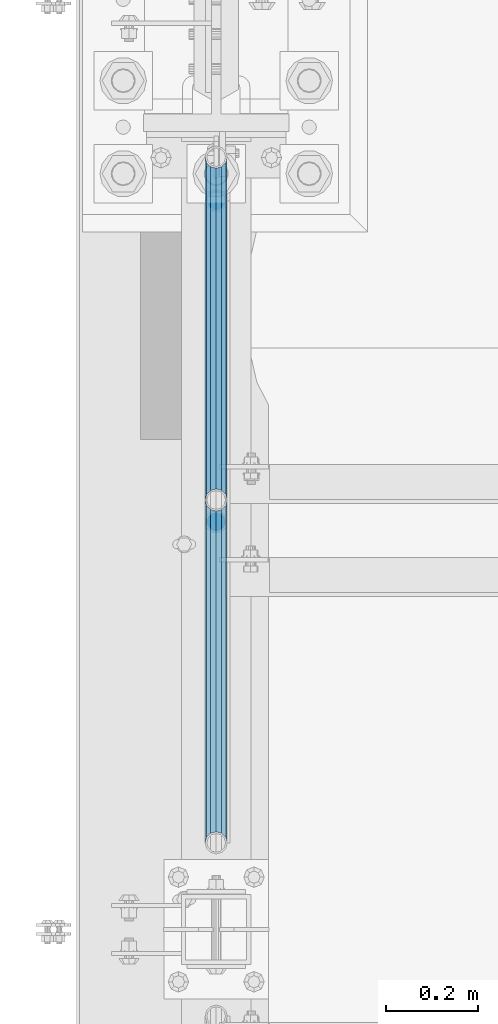
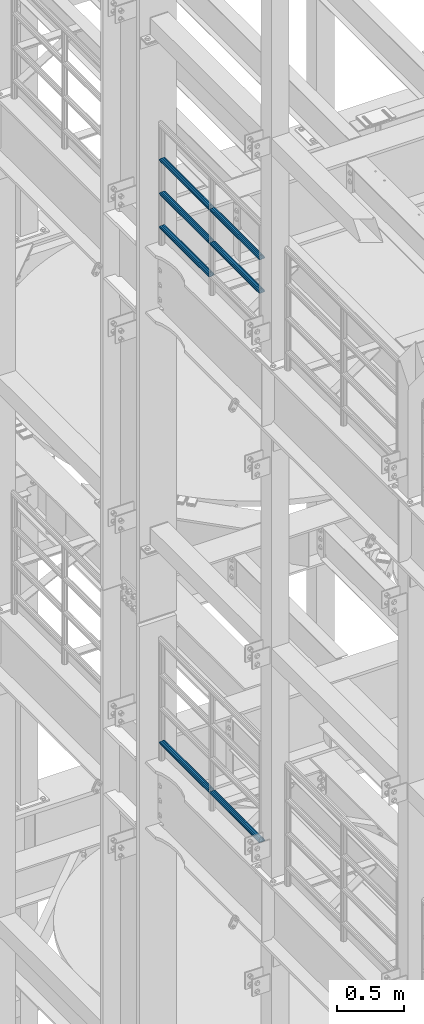
# One storey, part 1283 of 1876: 7 beams, 2 elements without a shape of their own.
"""IFC2X3 building model written with IfcOpenShell, lengths in millimetres."""

from ifc_helpers import new_model, si_unit, frame, origin_with_axes, place, context, subcontext, project, spatial, faceted_brep, material, type_object, element, aggregate, save


model = new_model("IFC2X3")

# Units and contexts
model_context = context("Model", 3, precision=1e-05, world=origin_with_axes())
body_context = subcontext(model_context, "Body", "Model", "MODEL_VIEW")
ifc_project = project(units=[si_unit("LENGTHUNIT", "METRE", prefix="MILLI"), si_unit("AREAUNIT", "SQUARE_METRE"), si_unit("VOLUMEUNIT", "CUBIC_METRE"), si_unit("MASSUNIT", "GRAM", prefix="KILO"), si_unit("TIMEUNIT", "SECOND"), si_unit("PLANEANGLEUNIT", "RADIAN"), si_unit("SOLIDANGLEUNIT", "STERADIAN"), si_unit("THERMODYNAMICTEMPERATUREUNIT", "DEGREE_CELSIUS"), si_unit("LUMINOUSINTENSITYUNIT", "LUMEN")], contexts=[model_context])

# Site, building, storey
site_placement = place(None, origin_with_axes())
site = spatial("IfcSite", under=ifc_project, at=site_placement, CompositionType="ELEMENT")
building_placement = place(site_placement, origin_with_axes())
building = spatial("IfcBuilding", under=site, at=building_placement, Name="Undefined", CompositionType="ELEMENT")
storey_placement = place(building_placement, origin_with_axes())
storey = spatial("IfcBuildingStorey", under=building, at=storey_placement, Name="Undefined", CompositionType="ELEMENT", Elevation=0.0)

# Assembly, beams
assembly_1_placement = place(storey_placement, origin_with_axes())
assembly_1 = element("IfcElementAssembly", 1, at=assembly_1_placement, inside=storey, Name="RAIL", AssemblyPlace="NOTDEFINED", PredefinedType="RIGID_FRAME")
ifc_material = material()
beam_type = type_object("IfcBeamType", Name="PIPE1-1/2SCH40", PredefinedType="NOTDEFINED")
beam_1_placement = place(assembly_1_placement, frame((-1.14353341410584e-11, 7275.195, 18145.125), z_axis=(0.0, 0.0, 1.0), x_axis=(0.0, -1.0, 0.0)))
beam_1 = element("IfcBeam", 2, at=beam_1_placement, type_object=beam_type, material=ifc_material, Name="RAIL", ObjectType="PIPE1-1/2SCH40", context=body_context, shape_type="Brep", body=[
    faceted_brep([(728.085307006683, -12.0649999999996, 20.8971929933177), (728.085307006683, -12.0649999999996, 15.8661214311796), (727.591878568821, -10.2235000000001, 17.7076214311819), (724.852500000002, 0.0, 20.4470000000001), (724.852500000002, 0.0, 24.130000000001), (727.591878568821, 10.2235000000001, 17.7076214311819), (728.085307006683, 12.0649999999996, 15.8661214311796), (728.085307006683, 12.0649999999996, 20.8971929933177), (748.982500000002, 24.1300000000001, 0.0), (736.917500000002, 20.8971929933186, 12.0649999999987), (736.917500000002, 20.8971929933186, -12.0649999999987), (733.727928437864, 17.7076214311801, 10.2235000000001), (736.467307006683, 20.4470000000001, 0.0), (733.727928437864, 17.7076214311801, -10.2235000000001), (728.085307006683, 12.0649999999996, -15.8661214311796), (728.085307006683, 12.0649999999996, -20.8971929933177), (727.591878568821, 10.2235000000001, -17.7076214311819), (724.852500000002, 0.0, -20.4470000000001), (724.852500000002, 0.0, -24.130000000001), (728.085307006683, -12.0649999999996, -15.8661214311796), (728.085307006683, -12.0649999999996, -20.8971929933177), (727.591878568821, -10.2235000000001, -17.7076214311819), (748.982500000002, -24.1300000000001, 0.0), (736.917500000002, -20.8971929933186, -12.0649999999987), (736.917500000002, -20.8971929933186, 12.0649999999987), (733.727928437864, -17.7076214311801, -10.2235000000001), (736.467307006683, -20.4470000000001, 0.0), (733.727928437864, -17.7076214311801, 10.2235000000001), (12.0650000000064, -20.8971929933177, -12.0649999999987), (20.8971929933249, -12.0650000000005, -20.8971929933177), (0.0, 24.1299999999992, 0.0), (12.0650000000064, 20.8971929933177, -12.0649999999987), (12.0650000000064, 20.8971929933177, 12.0649999999987), (20.8971929933249, 12.0650000000005, 20.8971929933177), (24.1300000000064, 0.0, 24.130000000001), (20.8971929933249, 12.0650000000005, -20.8971929933177), (24.1300000000063, 0.0, -24.130000000001), (24.1300000000063, 0.0, -20.4470000000001), (20.8971929933249, -12.0650000000005, -15.8661214311796), (21.3906214311868, -10.2235000000001, -17.7076214311819), (21.3906214311868, 10.2235000000001, -17.7076214311819), (20.8971929933249, 12.0650000000005, -15.8661214311796), (15.2545715621445, 17.7076214311801, -10.2235000000001), (12.5151929933249, 20.4470000000001, 0.0), (15.2545715621445, 17.7076214311801, 10.2235000000001), (20.8971929933249, 12.0650000000005, 15.8661214311796), (21.3906214311868, 10.2235000000001, 17.7076214311819), (24.1300000000064, 0.0, 20.4470000000001), (21.3906214311868, -10.2235000000001, 17.7076214311819), (20.8971929933249, -12.0650000000005, 15.8661214311796), (20.8971929933249, -12.0650000000005, 20.8971929933177), (12.0650000000064, -20.8971929933177, 12.0649999999987), (0.0, -24.1299999999992, 0.0), (15.2545715621445, -17.7076214311801, 10.2235000000001), (12.5151929933249, -20.4470000000001, 0.0), (15.2545715621445, -17.7076214311801, -10.2235000000001)], [[[0, 1, 2, 3, 4]], [[4, 3, 5, 6, 7]], [[8, 9, 10]], [[7, 6, 11, 12, 13, 14, 15, 10, 9]], [[16, 17, 18, 15, 14]], [[19, 20, 18, 17, 21]], [[22, 23, 24]], [[24, 23, 20, 19, 25, 26, 27, 1, 0]], [[28, 29, 20, 23]], [[30, 31, 32]], [[33, 34, 4, 7]], [[32, 33, 7, 9]], [[30, 32, 9, 8]], [[31, 30, 8, 10]], [[35, 31, 10, 15]], [[36, 35, 15, 18]], [[29, 36, 18, 20]], [[37, 36, 29, 38, 39]], [[40, 41, 35, 36, 37]], [[32, 31, 35, 41, 42, 43, 44, 45, 33]], [[33, 45, 46, 47, 34]], [[34, 47, 48, 49, 50]], [[34, 50, 0, 4]], [[50, 51, 24, 0]], [[51, 52, 22, 24]], [[52, 28, 23, 22]], [[51, 28, 52]], [[50, 49, 53, 54, 55, 38, 29, 28, 51]], [[55, 54, 26, 25]], [[21, 39, 38, 55, 25, 19]], [[37, 39, 21, 17]], [[40, 37, 17, 16]], [[42, 41, 40, 16, 14, 13]], [[43, 42, 13, 12]], [[44, 43, 12, 11]], [[5, 46, 45, 44, 11, 6]], [[47, 46, 5, 3]], [[48, 47, 3, 2]], [[53, 49, 48, 2, 1, 27]], [[54, 53, 27, 26]]]),
])
beam_2_placement = place(assembly_1_placement, frame((-1.81898940354586e-12, 5777.23, 18449.925), z_axis=(0.0, 0.0, -1.0), x_axis=(0.0, 1.0, 0.0)))
beam_2 = element("IfcBeam", 3, at=beam_2_placement, type_object=beam_type, material=ifc_material, Name="RAIL", ObjectType="PIPE1-1/2SCH40", context=body_context, shape_type="Brep", body=[
    faceted_brep([(0.0, 24.1299999999992, 0.0), (12.0650000000064, 20.8971929933177, -12.0649999999987), (12.0650000000064, 20.8971929933177, 12.0649999999987), (12.0650000000064, -20.8971929933177, 12.0649999999987), (12.0650000000064, -20.8971929933177, -12.0649999999987), (0.0, -24.1299999999992, 0.0), (20.8971929933249, -12.0650000000005, 20.8971929933177), (20.8971929933249, -12.0650000000005, 15.8661214311796), (15.2545715621445, -17.7076214311801, 10.2235000000001), (12.5151929933249, -20.4470000000001, 0.0), (15.2545715621445, -17.7076214311801, -10.2235000000001), (20.8971929933249, -12.0650000000005, -15.8661214311796), (20.8971929933249, -12.0650000000005, -20.8971929933177), (24.1300000000063, 0.0, -20.4470000000001), (24.1300000000063, 0.0, -24.130000000001), (21.3906214311868, -10.2235000000001, -17.7076214311819), (21.3906214311868, 10.2235000000001, -17.7076214311819), (20.8971929933249, 12.0650000000005, -15.8661214311796), (20.8971929933249, 12.0650000000005, -20.8971929933177), (15.2545715621445, 17.7076214311801, -10.2235000000001), (12.5151929933249, 20.4470000000001, 0.0), (15.2545715621445, 17.7076214311801, 10.2235000000001), (20.8971929933249, 12.0650000000005, 15.8661214311796), (20.8971929933249, 12.0650000000005, 20.8971929933177), (21.3906214311868, 10.2235000000001, 17.7076214311819), (24.1300000000064, 0.0, 20.4470000000001), (24.1300000000064, 0.0, 24.130000000001), (21.3906214311868, -10.2235000000001, 17.7076214311819), (748.982500000002, 24.1300000000001, 0.0), (736.917500000002, 20.8971929933186, -12.0649999999987), (728.085307006683, 12.0649999999996, -20.8971929933177), (748.982500000002, -24.1300000000001, 0.0), (736.917500000002, -20.8971929933186, -12.0649999999987), (736.917500000002, -20.8971929933186, 12.0649999999987), (728.085307006683, -12.0649999999996, 20.8971929933177), (728.085307006683, -12.0649999999996, -20.8971929933177), (724.852500000002, 0.0, -24.130000000001), (727.591878568821, 10.2235000000001, -17.7076214311819), (724.852500000002, 0.0, -20.4470000000001), (728.085307006683, 12.0649999999996, -15.8661214311796), (728.085307006683, -12.0649999999996, -15.8661214311796), (727.591878568821, -10.2235000000001, -17.7076214311819), (733.727928437864, -17.7076214311801, -10.2235000000001), (736.467307006683, -20.4470000000001, 0.0), (733.727928437864, -17.7076214311801, 10.2235000000001), (728.085307006683, -12.0649999999996, 15.8661214311796), (727.591878568821, -10.2235000000001, 17.7076214311819), (724.852500000002, 0.0, 20.4470000000001), (724.852500000002, 0.0, 24.130000000001), (728.085307006683, 12.0649999999996, 20.8971929933177), (736.917500000002, 20.8971929933186, 12.0649999999987), (728.085307006683, 12.0649999999996, 15.8661214311796), (733.727928437864, 17.7076214311801, 10.2235000000001), (736.467307006683, 20.4470000000001, 0.0), (733.727928437864, 17.7076214311801, -10.2235000000001), (727.591878568821, 10.2235000000001, 17.7076214311819)], [[[0, 1, 2]], [[3, 4, 5]], [[6, 7, 8, 9, 10, 11, 12, 4, 3]], [[13, 14, 12, 11, 15]], [[16, 17, 18, 14, 13]], [[2, 1, 18, 17, 19, 20, 21, 22, 23]], [[23, 22, 24, 25, 26]], [[26, 25, 27, 7, 6]], [[1, 0, 28, 29]], [[18, 1, 29, 30]], [[31, 32, 33]], [[6, 3, 33, 34]], [[3, 5, 31, 33]], [[5, 4, 32, 31]], [[4, 12, 35, 32]], [[12, 14, 36, 35]], [[14, 18, 30, 36]], [[37, 38, 36, 30, 39]], [[40, 35, 36, 38, 41]], [[33, 32, 35, 40, 42, 43, 44, 45, 34]], [[34, 45, 46, 47, 48]], [[26, 6, 34, 48]], [[2, 23, 49, 50]], [[23, 26, 48, 49]], [[0, 2, 50, 28]], [[28, 50, 29]], [[49, 51, 52, 53, 54, 39, 30, 29, 50]], [[48, 47, 55, 51, 49]], [[25, 24, 55, 47]], [[55, 24, 22, 21, 52, 51]], [[21, 20, 53, 52]], [[20, 19, 54, 53]], [[19, 17, 16, 37, 39, 54]], [[16, 13, 38, 37]], [[13, 15, 41, 38]], [[41, 15, 11, 10, 42, 40]], [[10, 9, 43, 42]], [[9, 8, 44, 43]], [[8, 7, 27, 46, 45, 44]], [[27, 25, 47, 46]]]),
])
beam_3_placement = place(assembly_1_placement, frame((-1.81898940354586e-12, 6526.2125, 18449.925), z_axis=(0.0, 0.0, -1.0), x_axis=(0.0, 1.0, 0.0)))
beam_3 = element("IfcBeam", 4, at=beam_3_placement, type_object=beam_type, material=ifc_material, Name="RAIL", ObjectType="PIPE1-1/2SCH40", context=body_context, shape_type="Brep", body=[
    faceted_brep([(0.0, 24.1299999999992, 0.0), (12.0650000000064, 20.8971929933177, -12.0649999999987), (12.0650000000064, 20.8971929933177, 12.0649999999987), (12.0650000000064, -20.8971929933177, 12.0649999999987), (12.0650000000064, -20.8971929933177, -12.0649999999987), (0.0, -24.1299999999992, 0.0), (20.8971929933249, -12.0650000000005, 20.8971929933177), (20.8971929933249, -12.0650000000005, 15.8661214311796), (15.2545715621445, -17.7076214311801, 10.2235000000001), (12.5151929933249, -20.4470000000001, 0.0), (15.2545715621445, -17.7076214311801, -10.2235000000001), (20.8971929933249, -12.0650000000005, -15.8661214311796), (20.8971929933249, -12.0650000000005, -20.8971929933177), (24.1300000000063, 0.0, -20.4470000000001), (24.1300000000063, 0.0, -24.130000000001), (21.3906214311868, -10.2235000000001, -17.7076214311819), (21.3906214311868, 10.2235000000001, -17.7076214311819), (20.8971929933249, 12.0650000000005, -15.8661214311796), (20.8971929933249, 12.0650000000005, -20.8971929933177), (15.2545715621445, 17.7076214311801, -10.2235000000001), (12.5151929933249, 20.4470000000001, 0.0), (15.2545715621445, 17.7076214311801, 10.2235000000001), (20.8971929933249, 12.0650000000005, 15.8661214311796), (20.8971929933249, 12.0650000000005, 20.8971929933177), (21.3906214311868, 10.2235000000001, 17.7076214311819), (24.1300000000064, 0.0, 20.4470000000001), (24.1300000000064, 0.0, 24.130000000001), (21.3906214311868, -10.2235000000001, 17.7076214311819), (748.982500000002, 24.1300000000001, 0.0), (736.917500000002, 20.8971929933186, -12.0649999999987), (728.085307006683, 12.0649999999996, -20.8971929933177), (748.982500000002, -24.1300000000001, 0.0), (736.917500000002, -20.8971929933186, -12.0649999999987), (736.917500000002, -20.8971929933186, 12.0649999999987), (728.085307006683, -12.0649999999996, 20.8971929933177), (728.085307006683, -12.0649999999996, -20.8971929933177), (724.852500000002, 0.0, -24.130000000001), (727.591878568821, 10.2235000000001, -17.7076214311819), (724.852500000002, 0.0, -20.4470000000001), (728.085307006683, 12.0649999999996, -15.8661214311796), (728.085307006683, -12.0649999999996, -15.8661214311796), (727.591878568821, -10.2235000000001, -17.7076214311819), (733.727928437864, -17.7076214311801, -10.2235000000001), (736.467307006683, -20.4470000000001, 0.0), (733.727928437864, -17.7076214311801, 10.2235000000001), (728.085307006683, -12.0649999999996, 15.8661214311796), (727.591878568821, -10.2235000000001, 17.7076214311819), (724.852500000002, 0.0, 20.4470000000001), (724.852500000002, 0.0, 24.130000000001), (728.085307006683, 12.0649999999996, 20.8971929933177), (736.917500000002, 20.8971929933186, 12.0649999999987), (728.085307006683, 12.0649999999996, 15.8661214311796), (733.727928437864, 17.7076214311801, 10.2235000000001), (736.467307006683, 20.4470000000001, 0.0), (733.727928437864, 17.7076214311801, -10.2235000000001), (727.591878568821, 10.2235000000001, 17.7076214311819)], [[[0, 1, 2]], [[3, 4, 5]], [[6, 7, 8, 9, 10, 11, 12, 4, 3]], [[13, 14, 12, 11, 15]], [[16, 17, 18, 14, 13]], [[2, 1, 18, 17, 19, 20, 21, 22, 23]], [[23, 22, 24, 25, 26]], [[26, 25, 27, 7, 6]], [[1, 0, 28, 29]], [[18, 1, 29, 30]], [[31, 32, 33]], [[6, 3, 33, 34]], [[3, 5, 31, 33]], [[5, 4, 32, 31]], [[4, 12, 35, 32]], [[12, 14, 36, 35]], [[14, 18, 30, 36]], [[37, 38, 36, 30, 39]], [[40, 35, 36, 38, 41]], [[33, 32, 35, 40, 42, 43, 44, 45, 34]], [[34, 45, 46, 47, 48]], [[26, 6, 34, 48]], [[2, 23, 49, 50]], [[23, 26, 48, 49]], [[0, 2, 50, 28]], [[28, 50, 29]], [[49, 51, 52, 53, 54, 39, 30, 29, 50]], [[48, 47, 55, 51, 49]], [[25, 24, 55, 47]], [[55, 24, 22, 21, 52, 51]], [[21, 20, 53, 52]], [[20, 19, 54, 53]], [[19, 17, 16, 37, 39, 54]], [[16, 13, 38, 37]], [[13, 15, 41, 38]], [[41, 15, 11, 10, 42, 40]], [[10, 9, 43, 42]], [[9, 8, 44, 43]], [[8, 7, 27, 46, 45, 44]], [[27, 25, 47, 46]]]),
])
beam_4_placement = place(assembly_1_placement, frame((-1.81898940354586e-12, 5777.23, 18754.725), z_axis=(0.0, 0.0, -1.0), x_axis=(0.0, 1.0, 0.0)))
beam_4 = element("IfcBeam", 5, at=beam_4_placement, type_object=beam_type, material=ifc_material, Name="RAIL", ObjectType="PIPE1-1/2SCH40", context=body_context, shape_type="Brep", body=[
    faceted_brep([(0.0, 24.1299999999992, 0.0), (12.0650000000064, 20.8971929933177, -12.0649999999987), (12.0650000000064, 20.8971929933177, 12.0649999999987), (12.0650000000064, -20.8971929933177, 12.0649999999987), (12.0650000000064, -20.8971929933177, -12.0649999999987), (0.0, -24.1299999999992, 0.0), (20.8971929933249, -12.0650000000005, 20.8971929933177), (20.8971929933249, -12.0650000000005, 15.8661214311796), (15.2545715621445, -17.7076214311801, 10.2235000000001), (12.5151929933249, -20.4470000000001, 0.0), (15.2545715621445, -17.7076214311801, -10.2235000000001), (20.8971929933249, -12.0650000000005, -15.8661214311796), (20.8971929933249, -12.0650000000005, -20.8971929933177), (24.1300000000063, 0.0, -20.4470000000001), (24.1300000000063, 0.0, -24.130000000001), (21.3906214311868, -10.2235000000001, -17.7076214311819), (21.3906214311868, 10.2235000000001, -17.7076214311819), (20.8971929933249, 12.0650000000005, -15.8661214311796), (20.8971929933249, 12.0650000000005, -20.8971929933177), (15.2545715621445, 17.7076214311801, -10.2235000000001), (12.5151929933249, 20.4470000000001, 0.0), (15.2545715621445, 17.7076214311801, 10.2235000000001), (20.8971929933249, 12.0650000000005, 15.8661214311796), (20.8971929933249, 12.0650000000005, 20.8971929933177), (21.3906214311868, 10.2235000000001, 17.7076214311819), (24.1300000000064, 0.0, 20.4470000000001), (24.1300000000064, 0.0, 24.130000000001), (21.3906214311868, -10.2235000000001, 17.7076214311819), (748.982500000002, 24.1300000000001, 0.0), (736.917500000002, 20.8971929933186, -12.0649999999987), (728.085307006683, 12.0649999999996, -20.8971929933177), (748.982500000002, -24.1300000000001, 0.0), (736.917500000002, -20.8971929933186, -12.0649999999987), (736.917500000002, -20.8971929933186, 12.0649999999987), (728.085307006683, -12.0649999999996, 20.8971929933177), (728.085307006683, -12.0649999999996, -20.8971929933177), (724.852500000002, 0.0, -24.130000000001), (727.591878568821, 10.2235000000001, -17.7076214311819), (724.852500000002, 0.0, -20.4470000000001), (728.085307006683, 12.0649999999996, -15.8661214311796), (728.085307006683, -12.0649999999996, -15.8661214311796), (727.591878568821, -10.2235000000001, -17.7076214311819), (733.727928437864, -17.7076214311801, -10.2235000000001), (736.467307006683, -20.4470000000001, 0.0), (733.727928437864, -17.7076214311801, 10.2235000000001), (728.085307006683, -12.0649999999996, 15.8661214311796), (727.591878568821, -10.2235000000001, 17.7076214311819), (724.852500000002, 0.0, 20.4470000000001), (724.852500000002, 0.0, 24.130000000001), (728.085307006683, 12.0649999999996, 20.8971929933177), (736.917500000002, 20.8971929933186, 12.0649999999987), (728.085307006683, 12.0649999999996, 15.8661214311796), (733.727928437864, 17.7076214311801, 10.2235000000001), (736.467307006683, 20.4470000000001, 0.0), (733.727928437864, 17.7076214311801, -10.2235000000001), (727.591878568821, 10.2235000000001, 17.7076214311819)], [[[0, 1, 2]], [[3, 4, 5]], [[6, 7, 8, 9, 10, 11, 12, 4, 3]], [[13, 14, 12, 11, 15]], [[16, 17, 18, 14, 13]], [[2, 1, 18, 17, 19, 20, 21, 22, 23]], [[23, 22, 24, 25, 26]], [[26, 25, 27, 7, 6]], [[1, 0, 28, 29]], [[18, 1, 29, 30]], [[31, 32, 33]], [[6, 3, 33, 34]], [[3, 5, 31, 33]], [[5, 4, 32, 31]], [[4, 12, 35, 32]], [[12, 14, 36, 35]], [[14, 18, 30, 36]], [[37, 38, 36, 30, 39]], [[40, 35, 36, 38, 41]], [[33, 32, 35, 40, 42, 43, 44, 45, 34]], [[34, 45, 46, 47, 48]], [[26, 6, 34, 48]], [[2, 23, 49, 50]], [[23, 26, 48, 49]], [[0, 2, 50, 28]], [[28, 50, 29]], [[49, 51, 52, 53, 54, 39, 30, 29, 50]], [[48, 47, 55, 51, 49]], [[25, 24, 55, 47]], [[55, 24, 22, 21, 52, 51]], [[21, 20, 53, 52]], [[20, 19, 54, 53]], [[19, 17, 16, 37, 39, 54]], [[16, 13, 38, 37]], [[13, 15, 41, 38]], [[41, 15, 11, 10, 42, 40]], [[10, 9, 43, 42]], [[9, 8, 44, 43]], [[8, 7, 27, 46, 45, 44]], [[27, 25, 47, 46]]]),
])
beam_5_placement = place(assembly_1_placement, frame((-1.81898940354586e-12, 6526.2125, 18754.725), z_axis=(0.0, 0.0, -1.0), x_axis=(0.0, 1.0, 0.0)))
beam_5 = element("IfcBeam", 6, at=beam_5_placement, type_object=beam_type, material=ifc_material, Name="RAIL", ObjectType="PIPE1-1/2SCH40", context=body_context, shape_type="Brep", body=[
    faceted_brep([(0.0, 24.1299999999992, 0.0), (12.0650000000064, 20.8971929933177, -12.0649999999987), (12.0650000000064, 20.8971929933177, 12.0649999999987), (12.0650000000064, -20.8971929933177, 12.0649999999987), (12.0650000000064, -20.8971929933177, -12.0649999999987), (0.0, -24.1299999999992, 0.0), (20.8971929933249, -12.0650000000005, 20.8971929933177), (20.8971929933249, -12.0650000000005, 15.8661214311796), (15.2545715621445, -17.7076214311801, 10.2235000000001), (12.5151929933249, -20.4470000000001, 0.0), (15.2545715621445, -17.7076214311801, -10.2235000000001), (20.8971929933249, -12.0650000000005, -15.8661214311796), (20.8971929933249, -12.0650000000005, -20.8971929933177), (24.1300000000063, 0.0, -20.4470000000001), (24.1300000000063, 0.0, -24.130000000001), (21.3906214311868, -10.2235000000001, -17.7076214311819), (21.3906214311868, 10.2235000000001, -17.7076214311819), (20.8971929933249, 12.0650000000005, -15.8661214311796), (20.8971929933249, 12.0650000000005, -20.8971929933177), (15.2545715621445, 17.7076214311801, -10.2235000000001), (12.5151929933249, 20.4470000000001, 0.0), (15.2545715621445, 17.7076214311801, 10.2235000000001), (20.8971929933249, 12.0650000000005, 15.8661214311796), (20.8971929933249, 12.0650000000005, 20.8971929933177), (21.3906214311868, 10.2235000000001, 17.7076214311819), (24.1300000000064, 0.0, 20.4470000000001), (24.1300000000064, 0.0, 24.130000000001), (21.3906214311868, -10.2235000000001, 17.7076214311819), (748.982500000002, 24.1300000000001, 0.0), (736.917500000002, 20.8971929933186, -12.0649999999987), (728.085307006683, 12.0649999999996, -20.8971929933177), (748.982500000002, -24.1300000000001, 0.0), (736.917500000002, -20.8971929933186, -12.0649999999987), (736.917500000002, -20.8971929933186, 12.0649999999987), (728.085307006683, -12.0649999999996, 20.8971929933177), (728.085307006683, -12.0649999999996, -20.8971929933177), (724.852500000002, 0.0, -24.130000000001), (727.591878568821, 10.2235000000001, -17.7076214311819), (724.852500000002, 0.0, -20.4470000000001), (728.085307006683, 12.0649999999996, -15.8661214311796), (728.085307006683, -12.0649999999996, -15.8661214311796), (727.591878568821, -10.2235000000001, -17.7076214311819), (733.727928437864, -17.7076214311801, -10.2235000000001), (736.467307006683, -20.4470000000001, 0.0), (733.727928437864, -17.7076214311801, 10.2235000000001), (728.085307006683, -12.0649999999996, 15.8661214311796), (727.591878568821, -10.2235000000001, 17.7076214311819), (724.852500000002, 0.0, 20.4470000000001), (724.852500000002, 0.0, 24.130000000001), (728.085307006683, 12.0649999999996, 20.8971929933177), (736.917500000002, 20.8971929933186, 12.0649999999987), (728.085307006683, 12.0649999999996, 15.8661214311796), (733.727928437864, 17.7076214311801, 10.2235000000001), (736.467307006683, 20.4470000000001, 0.0), (733.727928437864, 17.7076214311801, -10.2235000000001), (727.591878568821, 10.2235000000001, 17.7076214311819)], [[[0, 1, 2]], [[3, 4, 5]], [[6, 7, 8, 9, 10, 11, 12, 4, 3]], [[13, 14, 12, 11, 15]], [[16, 17, 18, 14, 13]], [[2, 1, 18, 17, 19, 20, 21, 22, 23]], [[23, 22, 24, 25, 26]], [[26, 25, 27, 7, 6]], [[1, 0, 28, 29]], [[18, 1, 29, 30]], [[31, 32, 33]], [[6, 3, 33, 34]], [[3, 5, 31, 33]], [[5, 4, 32, 31]], [[4, 12, 35, 32]], [[12, 14, 36, 35]], [[14, 18, 30, 36]], [[37, 38, 36, 30, 39]], [[40, 35, 36, 38, 41]], [[33, 32, 35, 40, 42, 43, 44, 45, 34]], [[34, 45, 46, 47, 48]], [[26, 6, 34, 48]], [[2, 23, 49, 50]], [[23, 26, 48, 49]], [[0, 2, 50, 28]], [[28, 50, 29]], [[49, 51, 52, 53, 54, 39, 30, 29, 50]], [[48, 47, 55, 51, 49]], [[25, 24, 55, 47]], [[55, 24, 22, 21, 52, 51]], [[21, 20, 53, 52]], [[20, 19, 54, 53]], [[19, 17, 16, 37, 39, 54]], [[16, 13, 38, 37]], [[13, 15, 41, 38]], [[41, 15, 11, 10, 42, 40]], [[10, 9, 43, 42]], [[9, 8, 44, 43]], [[8, 7, 27, 46, 45, 44]], [[27, 25, 47, 46]]]),
])
aggregate(assembly_1, [beam_1, beam_2, beam_3, beam_4, beam_5])

assembly_2_placement = place(storey_placement, origin_with_axes())
assembly_2 = element("IfcElementAssembly", 7, at=assembly_2_placement, inside=storey, Name="RAIL", AssemblyPlace="NOTDEFINED", PredefinedType="RIGID_FRAME")
beam_6_placement = place(assembly_2_placement, frame((-1.81898940354586e-12, 6526.2125, 13471.525), z_axis=(0.0, 0.0, 1.0), x_axis=(0.0, -1.0, 0.0)))
beam_6 = element("IfcBeam", 8, at=beam_6_placement, type_object=beam_type, material=ifc_material, Name="RAIL", ObjectType="PIPE1-1/2SCH40", context=body_context, shape_type="Brep", body=[
    faceted_brep([(728.085307006683, -12.0649999999996, 20.8971929933177), (728.085307006683, -12.0649999999996, 15.8661214311796), (727.591878568821, -10.2235000000001, 17.7076214311819), (724.852500000002, 0.0, 20.4470000000001), (724.852500000002, 0.0, 24.130000000001), (727.591878568821, 10.2235000000001, 17.7076214311819), (728.085307006683, 12.0649999999996, 15.8661214311796), (728.085307006683, 12.0649999999996, 20.8971929933177), (748.982500000002, 24.1300000000001, 0.0), (736.917500000002, 20.8971929933186, 12.0649999999987), (736.917500000002, 20.8971929933186, -12.0649999999987), (733.727928437864, 17.7076214311801, 10.2235000000001), (736.467307006683, 20.4470000000001, 0.0), (733.727928437864, 17.7076214311801, -10.2235000000001), (728.085307006683, 12.0649999999996, -15.8661214311796), (728.085307006683, 12.0649999999996, -20.8971929933177), (727.591878568821, 10.2235000000001, -17.7076214311819), (724.852500000002, 0.0, -20.4470000000001), (724.852500000002, 0.0, -24.130000000001), (728.085307006683, -12.0649999999996, -15.8661214311796), (728.085307006683, -12.0649999999996, -20.8971929933177), (727.591878568821, -10.2235000000001, -17.7076214311819), (748.982500000002, -24.1300000000001, 0.0), (736.917500000002, -20.8971929933186, -12.0649999999987), (736.917500000002, -20.8971929933186, 12.0649999999987), (733.727928437864, -17.7076214311801, -10.2235000000001), (736.467307006683, -20.4470000000001, 0.0), (733.727928437864, -17.7076214311801, 10.2235000000001), (12.0650000000064, -20.8971929933177, -12.0649999999987), (20.8971929933249, -12.0650000000005, -20.8971929933177), (0.0, 24.1299999999992, 0.0), (12.0650000000064, 20.8971929933177, -12.0649999999987), (12.0650000000064, 20.8971929933177, 12.0649999999987), (20.8971929933249, 12.0650000000005, 20.8971929933177), (24.1300000000064, 0.0, 24.130000000001), (20.8971929933249, 12.0650000000005, -20.8971929933177), (24.1300000000063, 0.0, -24.130000000001), (24.1300000000063, 0.0, -20.4470000000001), (20.8971929933249, -12.0650000000005, -15.8661214311796), (21.3906214311868, -10.2235000000001, -17.7076214311819), (21.3906214311868, 10.2235000000001, -17.7076214311819), (20.8971929933249, 12.0650000000005, -15.8661214311796), (15.2545715621445, 17.7076214311801, -10.2235000000001), (12.5151929933249, 20.4470000000001, 0.0), (15.2545715621445, 17.7076214311801, 10.2235000000001), (20.8971929933249, 12.0650000000005, 15.8661214311796), (21.3906214311868, 10.2235000000001, 17.7076214311819), (24.1300000000064, 0.0, 20.4470000000001), (21.3906214311868, -10.2235000000001, 17.7076214311819), (20.8971929933249, -12.0650000000005, 15.8661214311796), (20.8971929933249, -12.0650000000005, 20.8971929933177), (12.0650000000064, -20.8971929933177, 12.0649999999987), (0.0, -24.1299999999992, 0.0), (15.2545715621445, -17.7076214311801, 10.2235000000001), (12.5151929933249, -20.4470000000001, 0.0), (15.2545715621445, -17.7076214311801, -10.2235000000001)], [[[0, 1, 2, 3, 4]], [[4, 3, 5, 6, 7]], [[8, 9, 10]], [[7, 6, 11, 12, 13, 14, 15, 10, 9]], [[16, 17, 18, 15, 14]], [[19, 20, 18, 17, 21]], [[22, 23, 24]], [[24, 23, 20, 19, 25, 26, 27, 1, 0]], [[28, 29, 20, 23]], [[30, 31, 32]], [[33, 34, 4, 7]], [[32, 33, 7, 9]], [[30, 32, 9, 8]], [[31, 30, 8, 10]], [[35, 31, 10, 15]], [[36, 35, 15, 18]], [[29, 36, 18, 20]], [[37, 36, 29, 38, 39]], [[40, 41, 35, 36, 37]], [[32, 31, 35, 41, 42, 43, 44, 45, 33]], [[33, 45, 46, 47, 34]], [[34, 47, 48, 49, 50]], [[34, 50, 0, 4]], [[50, 51, 24, 0]], [[51, 52, 22, 24]], [[52, 28, 23, 22]], [[51, 28, 52]], [[50, 49, 53, 54, 55, 38, 29, 28, 51]], [[55, 54, 26, 25]], [[21, 39, 38, 55, 25, 19]], [[37, 39, 21, 17]], [[40, 37, 17, 16]], [[42, 41, 40, 16, 14, 13]], [[43, 42, 13, 12]], [[44, 43, 12, 11]], [[5, 46, 45, 44, 11, 6]], [[47, 46, 5, 3]], [[48, 47, 3, 2]], [[53, 49, 48, 2, 1, 27]], [[54, 53, 27, 26]]]),
])
beam_7_placement = place(assembly_2_placement, frame((-1.14353341410584e-11, 7275.195, 13471.525), z_axis=(0.0, 0.0, 1.0), x_axis=(0.0, -1.0, 0.0)))
beam_7 = element("IfcBeam", 9, at=beam_7_placement, type_object=beam_type, material=ifc_material, Name="RAIL", ObjectType="PIPE1-1/2SCH40", context=body_context, shape_type="Brep", body=[
    faceted_brep([(728.085307006683, -12.0649999999996, 20.8971929933177), (728.085307006683, -12.0649999999996, 15.8661214311796), (727.591878568821, -10.2235000000001, 17.7076214311819), (724.852500000002, 0.0, 20.4470000000001), (724.852500000002, 0.0, 24.130000000001), (727.591878568821, 10.2235000000001, 17.7076214311819), (728.085307006683, 12.0649999999996, 15.8661214311796), (728.085307006683, 12.0649999999996, 20.8971929933177), (748.982500000002, 24.1300000000001, 0.0), (736.917500000002, 20.8971929933186, 12.0649999999987), (736.917500000002, 20.8971929933186, -12.0649999999987), (733.727928437864, 17.7076214311801, 10.2235000000001), (736.467307006683, 20.4470000000001, 0.0), (733.727928437864, 17.7076214311801, -10.2235000000001), (728.085307006683, 12.0649999999996, -15.8661214311796), (728.085307006683, 12.0649999999996, -20.8971929933177), (727.591878568821, 10.2235000000001, -17.7076214311819), (724.852500000002, 0.0, -20.4470000000001), (724.852500000002, 0.0, -24.130000000001), (728.085307006683, -12.0649999999996, -15.8661214311796), (728.085307006683, -12.0649999999996, -20.8971929933177), (727.591878568821, -10.2235000000001, -17.7076214311819), (748.982500000002, -24.1300000000001, 0.0), (736.917500000002, -20.8971929933186, -12.0649999999987), (736.917500000002, -20.8971929933186, 12.0649999999987), (733.727928437864, -17.7076214311801, -10.2235000000001), (736.467307006683, -20.4470000000001, 0.0), (733.727928437864, -17.7076214311801, 10.2235000000001), (12.0650000000064, -20.8971929933177, -12.0649999999987), (20.8971929933249, -12.0650000000005, -20.8971929933177), (0.0, 24.1299999999992, 0.0), (12.0650000000064, 20.8971929933177, -12.0649999999987), (12.0650000000064, 20.8971929933177, 12.0649999999987), (20.8971929933249, 12.0650000000005, 20.8971929933177), (24.1300000000064, 0.0, 24.130000000001), (20.8971929933249, 12.0650000000005, -20.8971929933177), (24.1300000000063, 0.0, -24.130000000001), (24.1300000000063, 0.0, -20.4470000000001), (20.8971929933249, -12.0650000000005, -15.8661214311796), (21.3906214311868, -10.2235000000001, -17.7076214311819), (21.3906214311868, 10.2235000000001, -17.7076214311819), (20.8971929933249, 12.0650000000005, -15.8661214311796), (15.2545715621445, 17.7076214311801, -10.2235000000001), (12.5151929933249, 20.4470000000001, 0.0), (15.2545715621445, 17.7076214311801, 10.2235000000001), (20.8971929933249, 12.0650000000005, 15.8661214311796), (21.3906214311868, 10.2235000000001, 17.7076214311819), (24.1300000000064, 0.0, 20.4470000000001), (21.3906214311868, -10.2235000000001, 17.7076214311819), (20.8971929933249, -12.0650000000005, 15.8661214311796), (20.8971929933249, -12.0650000000005, 20.8971929933177), (12.0650000000064, -20.8971929933177, 12.0649999999987), (0.0, -24.1299999999992, 0.0), (15.2545715621445, -17.7076214311801, 10.2235000000001), (12.5151929933249, -20.4470000000001, 0.0), (15.2545715621445, -17.7076214311801, -10.2235000000001)], [[[0, 1, 2, 3, 4]], [[4, 3, 5, 6, 7]], [[8, 9, 10]], [[7, 6, 11, 12, 13, 14, 15, 10, 9]], [[16, 17, 18, 15, 14]], [[19, 20, 18, 17, 21]], [[22, 23, 24]], [[24, 23, 20, 19, 25, 26, 27, 1, 0]], [[28, 29, 20, 23]], [[30, 31, 32]], [[33, 34, 4, 7]], [[32, 33, 7, 9]], [[30, 32, 9, 8]], [[31, 30, 8, 10]], [[35, 31, 10, 15]], [[36, 35, 15, 18]], [[29, 36, 18, 20]], [[37, 36, 29, 38, 39]], [[40, 41, 35, 36, 37]], [[32, 31, 35, 41, 42, 43, 44, 45, 33]], [[33, 45, 46, 47, 34]], [[34, 47, 48, 49, 50]], [[34, 50, 0, 4]], [[50, 51, 24, 0]], [[51, 52, 22, 24]], [[52, 28, 23, 22]], [[51, 28, 52]], [[50, 49, 53, 54, 55, 38, 29, 28, 51]], [[55, 54, 26, 25]], [[21, 39, 38, 55, 25, 19]], [[37, 39, 21, 17]], [[40, 37, 17, 16]], [[42, 41, 40, 16, 14, 13]], [[43, 42, 13, 12]], [[44, 43, 12, 11]], [[5, 46, 45, 44, 11, 6]], [[47, 46, 5, 3]], [[48, 47, 3, 2]], [[53, 49, 48, 2, 1, 27]], [[54, 53, 27, 26]]]),
])
aggregate(assembly_2, [beam_6, beam_7])

save(model, "model.ifc")
